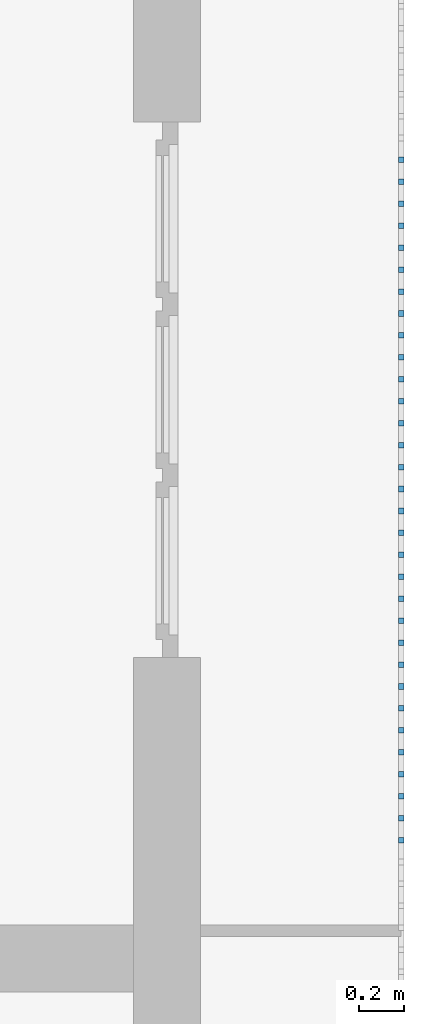
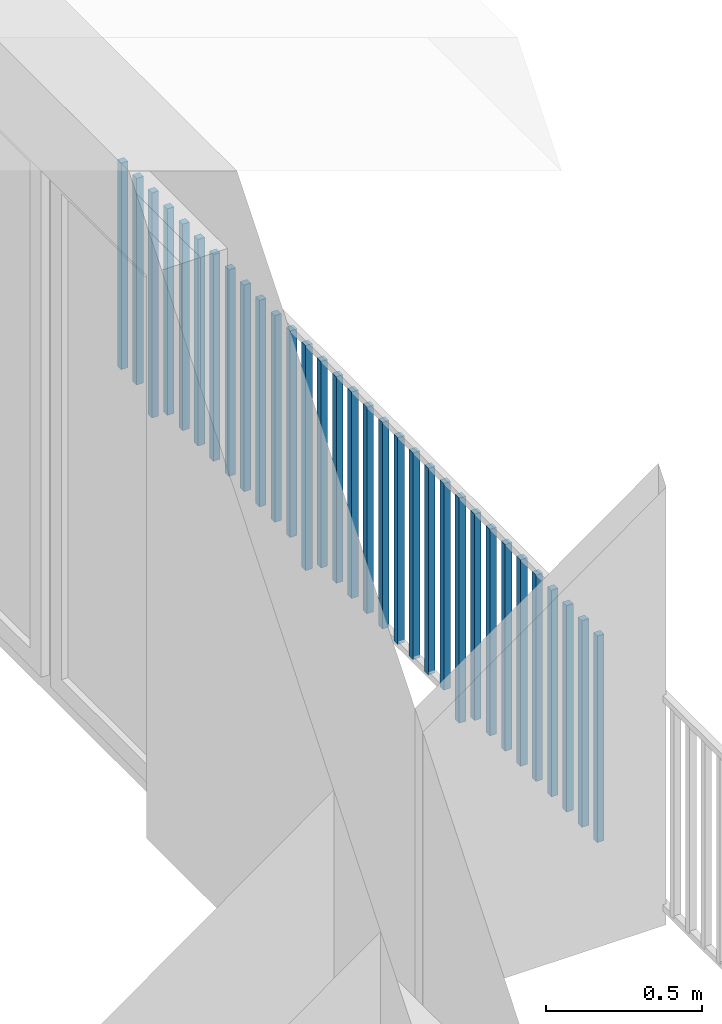
# One storey, part 46 of 54: 32 building element parts, 1 element without a shape of its own.
"""IFC4 building model written with IfcOpenShell, lengths in metres."""

from ifc_helpers import new_model, entity, si_unit, converted_unit, derived_unit, direction, frame, origin_with_axes, place, context, subcontext, project, spatial, polygons, material, type_object, element, aggregate, save


model = new_model("IFC4")

# Units and contexts
model_context = context("Model", 3, precision=1e-05, world=origin_with_axes(), true_north=direction((0.0, 1.0)))
body_context = subcontext(model_context, "Body", "Model", "MODEL_VIEW")
ifc_project = project(units=[si_unit("LENGTHUNIT", "METRE"), si_unit("AREAUNIT", "SQUARE_METRE"), si_unit("VOLUMEUNIT", "CUBIC_METRE"), converted_unit("PLANEANGLEUNIT", "DEGREE", entity("IfcPlaneAngleMeasure", 0.0174532925199), si_unit("PLANEANGLEUNIT", "RADIAN"), dimensions=[0, 0, 0, 0, 0, 0, 0]), converted_unit("TIMEUNIT", "Year", entity("IfcTimeMeasure", 31556926.0), si_unit("TIMEUNIT", "SECOND"), dimensions=[0, 0, 1, 0, 0, 0, 0]), si_unit("MASSUNIT", "GRAM", prefix="KILO"), si_unit("THERMODYNAMICTEMPERATUREUNIT", "DEGREE_CELSIUS"), si_unit("LUMINOUSINTENSITYUNIT", "LUMEN"), si_unit("ENERGYUNIT", "JOULE", prefix="MEGA"), derived_unit("THERMALCONDUCTANCEUNIT", [(si_unit("POWERUNIT", "WATT"), 1), (si_unit("LENGTHUNIT", "METRE"), -1), (si_unit("THERMODYNAMICTEMPERATUREUNIT", "KELVIN"), -1)]), derived_unit("SPECIFICHEATCAPACITYUNIT", [(si_unit("ENERGYUNIT", "JOULE"), 1), (si_unit("MASSUNIT", "GRAM", prefix="KILO"), -1), (si_unit("THERMODYNAMICTEMPERATUREUNIT", "KELVIN"), -1)]), derived_unit("MASSDENSITYUNIT", [(si_unit("MASSUNIT", "GRAM", prefix="KILO"), 1), (si_unit("VOLUMEUNIT", "CUBIC_METRE"), -1)])], contexts=[model_context])

# Site, building, storey, space
site_placement = place(None, origin_with_axes())
site = spatial("IfcSite", under=ifc_project, at=site_placement, CompositionType="ELEMENT")
building_placement = place(site_placement, origin_with_axes())
building = spatial("IfcBuilding", under=site, at=building_placement, CompositionType="ELEMENT")
storey_placement = place(building_placement, frame((0.0, 0.0, 6.29), z_axis=(0.0, 0.0, 1.0), x_axis=(1.0, 0.0, 0.0)))
storey = spatial("IfcBuildingStorey", under=building, at=storey_placement, Name="2. Geschoss", CompositionType="ELEMENT", Elevation=6.29)
space_placement = place(storey_placement, frame((10.2378006196, 9.82118769833, 0.0), z_axis=(0.0, 0.0, 1.0), x_axis=(-1.0, 0.0, 0.0)))
space = spatial("IfcSpace", under=storey, at=space_placement, CompositionType="ELEMENT", PredefinedType="EXTERNAL")

# Railing, building element parts
railing_type = type_object("IfcRailingType", PredefinedType="NOTDEFINED")
railing_placement = place(space_placement, frame((0.0, -7.06315681498e-08, 0.0), z_axis=(0.0, 0.0, 1.0), x_axis=(-1.0, 0.0, 0.0)))
railing = element("IfcRailing", 1, at=railing_placement, inside=space, type_object=railing_type, PredefinedType="NOTDEFINED")
ifc_material = material()
building_element_part_1_placement = place(railing_placement, origin_with_axes())
building_element_part_1 = element("IfcBuildingElementPart", 2, at=building_element_part_1_placement, material=ifc_material, PredefinedType="NOTDEFINED", context=body_context, shape_type="Tessellation", body=[
    polygons([(0.0125, -7.75583333333, 0.07), (-0.0125, -7.75583333333, 0.07), (-0.0125, -7.75583333333, 0.8775), (0.0125, -7.75583333333, 0.8775), (0.0125, -7.78083333333, 0.07), (-0.0125, -7.78083333333, 0.07), (-0.0125, -7.78083333333, 0.8775), (0.0125, -7.78083333333, 0.8775)], [[[1, 2, 3, 4]], [[1, 5, 6, 2]], [[2, 6, 7, 3]], [[4, 3, 7, 8]], [[5, 1, 4, 8]], [[6, 5, 8, 7]]], closed=True),
])
building_element_part_2_placement = place(railing_placement, origin_with_axes())
building_element_part_2 = element("IfcBuildingElementPart", 3, at=building_element_part_2_placement, material=ifc_material, PredefinedType="NOTDEFINED", context=body_context, shape_type="Tessellation", body=[
    polygons([(0.0125, -7.6575, 0.07), (-0.0125, -7.6575, 0.07), (-0.0125, -7.6575, 0.8775), (0.0125, -7.6575, 0.8775), (0.0125, -7.6825, 0.07), (-0.0125, -7.6825, 0.07), (-0.0125, -7.6825, 0.8775), (0.0125, -7.6825, 0.8775)], [[[1, 2, 3, 4]], [[1, 5, 6, 2]], [[2, 6, 7, 3]], [[4, 3, 7, 8]], [[5, 1, 4, 8]], [[6, 5, 8, 7]]], closed=True),
])
building_element_part_3_placement = place(railing_placement, origin_with_axes())
building_element_part_3 = element("IfcBuildingElementPart", 4, at=building_element_part_3_placement, material=ifc_material, PredefinedType="NOTDEFINED", context=body_context, shape_type="Tessellation", body=[
    polygons([(0.0125, -7.55916666667, 0.07), (-0.0125, -7.55916666667, 0.07), (-0.0125, -7.55916666667, 0.8775), (0.0125, -7.55916666667, 0.8775), (0.0125, -7.58416666667, 0.07), (-0.0125, -7.58416666667, 0.07), (-0.0125, -7.58416666667, 0.8775), (0.0125, -7.58416666667, 0.8775)], [[[1, 2, 3, 4]], [[1, 5, 6, 2]], [[2, 6, 7, 3]], [[4, 3, 7, 8]], [[5, 1, 4, 8]], [[6, 5, 8, 7]]], closed=True),
])
building_element_part_4_placement = place(railing_placement, origin_with_axes())
building_element_part_4 = element("IfcBuildingElementPart", 5, at=building_element_part_4_placement, material=ifc_material, PredefinedType="NOTDEFINED", context=body_context, shape_type="Tessellation", body=[
    polygons([(0.0125, -7.46083333333, 0.07), (-0.0125, -7.46083333333, 0.07), (-0.0125, -7.46083333333, 0.8775), (0.0125, -7.46083333333, 0.8775), (0.0125, -7.48583333333, 0.07), (-0.0125, -7.48583333333, 0.07), (-0.0125, -7.48583333333, 0.8775), (0.0125, -7.48583333333, 0.8775)], [[[1, 2, 3, 4]], [[1, 5, 6, 2]], [[2, 6, 7, 3]], [[4, 3, 7, 8]], [[5, 1, 4, 8]], [[6, 5, 8, 7]]], closed=True),
])
building_element_part_5_placement = place(railing_placement, origin_with_axes())
building_element_part_5 = element("IfcBuildingElementPart", 6, at=building_element_part_5_placement, material=ifc_material, PredefinedType="NOTDEFINED", context=body_context, shape_type="Tessellation", body=[
    polygons([(0.0125, -7.3625, 0.07), (-0.0125, -7.3625, 0.07), (-0.0125, -7.3625, 0.8775), (0.0125, -7.3625, 0.8775), (0.0125, -7.3875, 0.07), (-0.0125, -7.3875, 0.07), (-0.0125, -7.3875, 0.8775), (0.0125, -7.3875, 0.8775)], [[[1, 2, 3, 4]], [[1, 5, 6, 2]], [[2, 6, 7, 3]], [[4, 3, 7, 8]], [[5, 1, 4, 8]], [[6, 5, 8, 7]]], closed=True),
])
building_element_part_6_placement = place(railing_placement, origin_with_axes())
building_element_part_6 = element("IfcBuildingElementPart", 7, at=building_element_part_6_placement, material=ifc_material, PredefinedType="NOTDEFINED", context=body_context, shape_type="Tessellation", body=[
    polygons([(0.0125, -7.26416666667, 0.07), (-0.0125, -7.26416666667, 0.07), (-0.0125, -7.26416666667, 0.8775), (0.0125, -7.26416666667, 0.8775), (0.0125, -7.28916666667, 0.07), (-0.0125, -7.28916666667, 0.07), (-0.0125, -7.28916666667, 0.8775), (0.0125, -7.28916666667, 0.8775)], [[[1, 2, 3, 4]], [[1, 5, 6, 2]], [[2, 6, 7, 3]], [[4, 3, 7, 8]], [[5, 1, 4, 8]], [[6, 5, 8, 7]]], closed=True),
])
building_element_part_7_placement = place(railing_placement, origin_with_axes())
building_element_part_7 = element("IfcBuildingElementPart", 8, at=building_element_part_7_placement, material=ifc_material, PredefinedType="NOTDEFINED", context=body_context, shape_type="Tessellation", body=[
    polygons([(0.0125, -7.16583333333, 0.07), (-0.0125, -7.16583333333, 0.07), (-0.0125, -7.16583333333, 0.8775), (0.0125, -7.16583333333, 0.8775), (0.0125, -7.19083333333, 0.07), (-0.0125, -7.19083333333, 0.07), (-0.0125, -7.19083333333, 0.8775), (0.0125, -7.19083333333, 0.8775)], [[[1, 2, 3, 4]], [[1, 5, 6, 2]], [[2, 6, 7, 3]], [[4, 3, 7, 8]], [[5, 1, 4, 8]], [[6, 5, 8, 7]]], closed=True),
])
building_element_part_8_placement = place(railing_placement, origin_with_axes())
building_element_part_8 = element("IfcBuildingElementPart", 9, at=building_element_part_8_placement, material=ifc_material, PredefinedType="NOTDEFINED", context=body_context, shape_type="Tessellation", body=[
    polygons([(0.0125, -7.0675, 0.07), (-0.0125, -7.0675, 0.07), (-0.0125, -7.0675, 0.8775), (0.0125, -7.0675, 0.8775), (0.0125, -7.0925, 0.07), (-0.0125, -7.0925, 0.07), (-0.0125, -7.0925, 0.8775), (0.0125, -7.0925, 0.8775)], [[[1, 2, 3, 4]], [[1, 5, 6, 2]], [[2, 6, 7, 3]], [[4, 3, 7, 8]], [[5, 1, 4, 8]], [[6, 5, 8, 7]]], closed=True),
])
building_element_part_9_placement = place(railing_placement, origin_with_axes())
building_element_part_9 = element("IfcBuildingElementPart", 10, at=building_element_part_9_placement, material=ifc_material, PredefinedType="NOTDEFINED", context=body_context, shape_type="Tessellation", body=[
    polygons([(0.0125, -6.96916666667, 0.07), (-0.0125, -6.96916666667, 0.07), (-0.0125, -6.96916666667, 0.8775), (0.0125, -6.96916666667, 0.8775), (0.0125, -6.99416666667, 0.07), (-0.0125, -6.99416666667, 0.07), (-0.0125, -6.99416666667, 0.8775), (0.0125, -6.99416666667, 0.8775)], [[[1, 2, 3, 4]], [[1, 5, 6, 2]], [[2, 6, 7, 3]], [[4, 3, 7, 8]], [[5, 1, 4, 8]], [[6, 5, 8, 7]]], closed=True),
])
building_element_part_10_placement = place(railing_placement, origin_with_axes())
building_element_part_10 = element("IfcBuildingElementPart", 11, at=building_element_part_10_placement, material=ifc_material, PredefinedType="NOTDEFINED", context=body_context, shape_type="Tessellation", body=[
    polygons([(0.0125, -6.87083333333, 0.0), (-0.0125, -6.87083333333, 0.0), (-0.0125, -6.87083333333, 0.88), (0.0125, -6.87083333333, 0.88), (0.0125, -6.89583333333, 0.0), (-0.0125, -6.89583333333, 0.0), (-0.0125, -6.89583333333, 0.88), (0.0125, -6.89583333333, 0.88)], [[[1, 2, 3, 4]], [[1, 5, 6, 2]], [[2, 6, 7, 3]], [[4, 3, 7, 8]], [[5, 1, 4, 8]], [[6, 5, 8, 7]]], closed=True),
])
building_element_part_11_placement = place(railing_placement, origin_with_axes())
building_element_part_11 = element("IfcBuildingElementPart", 12, at=building_element_part_11_placement, material=ifc_material, PredefinedType="NOTDEFINED", context=body_context, shape_type="Tessellation", body=[
    polygons([(0.0125, -6.7725, 0.07), (-0.0125, -6.7725, 0.07), (-0.0125, -6.7725, 0.8775), (0.0125, -6.7725, 0.8775), (0.0125, -6.7975, 0.07), (-0.0125, -6.7975, 0.07), (-0.0125, -6.7975, 0.8775), (0.0125, -6.7975, 0.8775)], [[[1, 2, 3, 4]], [[1, 5, 6, 2]], [[2, 6, 7, 3]], [[4, 3, 7, 8]], [[5, 1, 4, 8]], [[6, 5, 8, 7]]], closed=True),
])
building_element_part_12_placement = place(railing_placement, origin_with_axes())
building_element_part_12 = element("IfcBuildingElementPart", 13, at=building_element_part_12_placement, material=ifc_material, PredefinedType="NOTDEFINED", context=body_context, shape_type="Tessellation", body=[
    polygons([(0.0125, -6.67416666667, 0.07), (-0.0125, -6.67416666667, 0.07), (-0.0125, -6.67416666667, 0.8775), (0.0125, -6.67416666667, 0.8775), (0.0125, -6.69916666667, 0.07), (-0.0125, -6.69916666667, 0.07), (-0.0125, -6.69916666667, 0.8775), (0.0125, -6.69916666667, 0.8775)], [[[1, 2, 3, 4]], [[1, 5, 6, 2]], [[2, 6, 7, 3]], [[4, 3, 7, 8]], [[5, 1, 4, 8]], [[6, 5, 8, 7]]], closed=True),
])
building_element_part_13_placement = place(railing_placement, origin_with_axes())
building_element_part_13 = element("IfcBuildingElementPart", 14, at=building_element_part_13_placement, material=ifc_material, PredefinedType="NOTDEFINED", context=body_context, shape_type="Tessellation", body=[
    polygons([(0.0125, -6.57583333333, 0.07), (-0.0125, -6.57583333333, 0.07), (-0.0125, -6.57583333333, 0.8775), (0.0125, -6.57583333333, 0.8775), (0.0125, -6.60083333333, 0.07), (-0.0125, -6.60083333333, 0.07), (-0.0125, -6.60083333333, 0.8775), (0.0125, -6.60083333333, 0.8775)], [[[1, 2, 3, 4]], [[1, 5, 6, 2]], [[2, 6, 7, 3]], [[4, 3, 7, 8]], [[5, 1, 4, 8]], [[6, 5, 8, 7]]], closed=True),
])
building_element_part_14_placement = place(railing_placement, origin_with_axes())
building_element_part_14 = element("IfcBuildingElementPart", 15, at=building_element_part_14_placement, material=ifc_material, PredefinedType="NOTDEFINED", context=body_context, shape_type="Tessellation", body=[
    polygons([(0.0125, -6.4775, 0.07), (-0.0125, -6.4775, 0.07), (-0.0125, -6.4775, 0.8775), (0.0125, -6.4775, 0.8775), (0.0125, -6.5025, 0.07), (-0.0125, -6.5025, 0.07), (-0.0125, -6.5025, 0.8775), (0.0125, -6.5025, 0.8775)], [[[1, 2, 3, 4]], [[1, 5, 6, 2]], [[2, 6, 7, 3]], [[4, 3, 7, 8]], [[5, 1, 4, 8]], [[6, 5, 8, 7]]], closed=True),
])
building_element_part_15_placement = place(railing_placement, origin_with_axes())
building_element_part_15 = element("IfcBuildingElementPart", 16, at=building_element_part_15_placement, material=ifc_material, PredefinedType="NOTDEFINED", context=body_context, shape_type="Tessellation", body=[
    polygons([(0.0125, -6.37916666667, 0.07), (-0.0125, -6.37916666667, 0.07), (-0.0125, -6.37916666667, 0.8775), (0.0125, -6.37916666667, 0.8775), (0.0125, -6.40416666667, 0.07), (-0.0125, -6.40416666667, 0.07), (-0.0125, -6.40416666667, 0.8775), (0.0125, -6.40416666667, 0.8775)], [[[1, 2, 3, 4]], [[1, 5, 6, 2]], [[2, 6, 7, 3]], [[4, 3, 7, 8]], [[5, 1, 4, 8]], [[6, 5, 8, 7]]], closed=True),
])
building_element_part_16_placement = place(railing_placement, origin_with_axes())
building_element_part_16 = element("IfcBuildingElementPart", 17, at=building_element_part_16_placement, material=ifc_material, PredefinedType="NOTDEFINED", context=body_context, shape_type="Tessellation", body=[
    polygons([(0.0125, -6.28083333333, 0.07), (-0.0125, -6.28083333333, 0.07), (-0.0125, -6.28083333333, 0.8775), (0.0125, -6.28083333333, 0.8775), (0.0125, -6.30583333333, 0.07), (-0.0125, -6.30583333333, 0.07), (-0.0125, -6.30583333333, 0.8775), (0.0125, -6.30583333333, 0.8775)], [[[1, 2, 3, 4]], [[1, 5, 6, 2]], [[2, 6, 7, 3]], [[4, 3, 7, 8]], [[5, 1, 4, 8]], [[6, 5, 8, 7]]], closed=True),
])
building_element_part_17_placement = place(railing_placement, origin_with_axes())
building_element_part_17 = element("IfcBuildingElementPart", 18, at=building_element_part_17_placement, material=ifc_material, PredefinedType="NOTDEFINED", context=body_context, shape_type="Tessellation", body=[
    polygons([(0.0125, -6.1825, 0.07), (-0.0125, -6.1825, 0.07), (-0.0125, -6.1825, 0.8775), (0.0125, -6.1825, 0.8775), (0.0125, -6.2075, 0.07), (-0.0125, -6.2075, 0.07), (-0.0125, -6.2075, 0.8775), (0.0125, -6.2075, 0.8775)], [[[1, 2, 3, 4]], [[1, 5, 6, 2]], [[2, 6, 7, 3]], [[4, 3, 7, 8]], [[5, 1, 4, 8]], [[6, 5, 8, 7]]], closed=True),
])
building_element_part_18_placement = place(railing_placement, origin_with_axes())
building_element_part_18 = element("IfcBuildingElementPart", 19, at=building_element_part_18_placement, material=ifc_material, PredefinedType="NOTDEFINED", context=body_context, shape_type="Tessellation", body=[
    polygons([(0.0125, -6.08416666667, 0.07), (-0.0125, -6.08416666667, 0.07), (-0.0125, -6.08416666667, 0.8775), (0.0125, -6.08416666667, 0.8775), (0.0125, -6.10916666667, 0.07), (-0.0125, -6.10916666667, 0.07), (-0.0125, -6.10916666667, 0.8775), (0.0125, -6.10916666667, 0.8775)], [[[1, 2, 3, 4]], [[1, 5, 6, 2]], [[2, 6, 7, 3]], [[4, 3, 7, 8]], [[5, 1, 4, 8]], [[6, 5, 8, 7]]], closed=True),
])
building_element_part_19_placement = place(railing_placement, origin_with_axes())
building_element_part_19 = element("IfcBuildingElementPart", 20, at=building_element_part_19_placement, material=ifc_material, PredefinedType="NOTDEFINED", context=body_context, shape_type="Tessellation", body=[
    polygons([(0.0125, -5.98583333333, 0.07), (-0.0125, -5.98583333333, 0.07), (-0.0125, -5.98583333333, 0.8775), (0.0125, -5.98583333333, 0.8775), (0.0125, -6.01083333333, 0.07), (-0.0125, -6.01083333333, 0.07), (-0.0125, -6.01083333333, 0.8775), (0.0125, -6.01083333333, 0.8775)], [[[1, 2, 3, 4]], [[1, 5, 6, 2]], [[2, 6, 7, 3]], [[4, 3, 7, 8]], [[5, 1, 4, 8]], [[6, 5, 8, 7]]], closed=True),
])
building_element_part_20_placement = place(railing_placement, origin_with_axes())
building_element_part_20 = element("IfcBuildingElementPart", 21, at=building_element_part_20_placement, material=ifc_material, PredefinedType="NOTDEFINED", context=body_context, shape_type="Tessellation", body=[
    polygons([(0.0125, -5.8875, 0.0), (-0.0125, -5.8875, 0.0), (-0.0125, -5.8875, 0.88), (0.0125, -5.8875, 0.88), (0.0125, -5.9125, 0.0), (-0.0125, -5.9125, 0.0), (-0.0125, -5.9125, 0.88), (0.0125, -5.9125, 0.88)], [[[1, 2, 3, 4]], [[1, 5, 6, 2]], [[2, 6, 7, 3]], [[4, 3, 7, 8]], [[5, 1, 4, 8]], [[6, 5, 8, 7]]], closed=True),
])
building_element_part_21_placement = place(railing_placement, origin_with_axes())
building_element_part_21 = element("IfcBuildingElementPart", 22, at=building_element_part_21_placement, material=ifc_material, PredefinedType="NOTDEFINED", context=body_context, shape_type="Tessellation", body=[
    polygons([(0.0125, -5.78916666667, 0.07), (-0.0125, -5.78916666667, 0.07), (-0.0125, -5.78916666667, 0.8775), (0.0125, -5.78916666667, 0.8775), (0.0125, -5.81416666667, 0.07), (-0.0125, -5.81416666667, 0.07), (-0.0125, -5.81416666667, 0.8775), (0.0125, -5.81416666667, 0.8775)], [[[1, 2, 3, 4]], [[1, 5, 6, 2]], [[2, 6, 7, 3]], [[4, 3, 7, 8]], [[5, 1, 4, 8]], [[6, 5, 8, 7]]], closed=True),
])
building_element_part_22_placement = place(railing_placement, origin_with_axes())
building_element_part_22 = element("IfcBuildingElementPart", 23, at=building_element_part_22_placement, material=ifc_material, PredefinedType="NOTDEFINED", context=body_context, shape_type="Tessellation", body=[
    polygons([(0.0125, -5.69083333333, 0.07), (-0.0125, -5.69083333333, 0.07), (-0.0125, -5.69083333333, 0.8775), (0.0125, -5.69083333333, 0.8775), (0.0125, -5.71583333333, 0.07), (-0.0125, -5.71583333333, 0.07), (-0.0125, -5.71583333333, 0.8775), (0.0125, -5.71583333333, 0.8775)], [[[1, 2, 3, 4]], [[1, 5, 6, 2]], [[2, 6, 7, 3]], [[4, 3, 7, 8]], [[5, 1, 4, 8]], [[6, 5, 8, 7]]], closed=True),
])
building_element_part_23_placement = place(railing_placement, origin_with_axes())
building_element_part_23 = element("IfcBuildingElementPart", 24, at=building_element_part_23_placement, material=ifc_material, PredefinedType="NOTDEFINED", context=body_context, shape_type="Tessellation", body=[
    polygons([(0.0125, -5.5925, 0.07), (-0.0125, -5.5925, 0.07), (-0.0125, -5.5925, 0.8775), (0.0125, -5.5925, 0.8775), (0.0125, -5.6175, 0.07), (-0.0125, -5.6175, 0.07), (-0.0125, -5.6175, 0.8775), (0.0125, -5.6175, 0.8775)], [[[1, 2, 3, 4]], [[1, 5, 6, 2]], [[2, 6, 7, 3]], [[4, 3, 7, 8]], [[5, 1, 4, 8]], [[6, 5, 8, 7]]], closed=True),
])
building_element_part_24_placement = place(railing_placement, origin_with_axes())
building_element_part_24 = element("IfcBuildingElementPart", 25, at=building_element_part_24_placement, material=ifc_material, PredefinedType="NOTDEFINED", context=body_context, shape_type="Tessellation", body=[
    polygons([(0.0125, -5.49416666667, 0.07), (-0.0125, -5.49416666667, 0.07), (-0.0125, -5.49416666667, 0.8775), (0.0125, -5.49416666667, 0.8775), (0.0125, -5.51916666667, 0.07), (-0.0125, -5.51916666667, 0.07), (-0.0125, -5.51916666667, 0.8775), (0.0125, -5.51916666667, 0.8775)], [[[1, 2, 3, 4]], [[1, 5, 6, 2]], [[2, 6, 7, 3]], [[4, 3, 7, 8]], [[5, 1, 4, 8]], [[6, 5, 8, 7]]], closed=True),
])
building_element_part_25_placement = place(railing_placement, origin_with_axes())
building_element_part_25 = element("IfcBuildingElementPart", 26, at=building_element_part_25_placement, material=ifc_material, PredefinedType="NOTDEFINED", context=body_context, shape_type="Tessellation", body=[
    polygons([(0.0125, -5.39583333333, 0.07), (-0.0125, -5.39583333333, 0.07), (-0.0125, -5.39583333333, 0.8775), (0.0125, -5.39583333333, 0.8775), (0.0125, -5.42083333333, 0.07), (-0.0125, -5.42083333333, 0.07), (-0.0125, -5.42083333333, 0.8775), (0.0125, -5.42083333333, 0.8775)], [[[1, 2, 3, 4]], [[1, 5, 6, 2]], [[2, 6, 7, 3]], [[4, 3, 7, 8]], [[5, 1, 4, 8]], [[6, 5, 8, 7]]], closed=True),
])
building_element_part_26_placement = place(railing_placement, origin_with_axes())
building_element_part_26 = element("IfcBuildingElementPart", 27, at=building_element_part_26_placement, material=ifc_material, PredefinedType="NOTDEFINED", context=body_context, shape_type="Tessellation", body=[
    polygons([(0.0125, -5.2975, 0.07), (-0.0125, -5.2975, 0.07), (-0.0125, -5.2975, 0.8775), (0.0125, -5.2975, 0.8775), (0.0125, -5.3225, 0.07), (-0.0125, -5.3225, 0.07), (-0.0125, -5.3225, 0.8775), (0.0125, -5.3225, 0.8775)], [[[1, 2, 3, 4]], [[1, 5, 6, 2]], [[2, 6, 7, 3]], [[4, 3, 7, 8]], [[5, 1, 4, 8]], [[6, 5, 8, 7]]], closed=True),
])
building_element_part_27_placement = place(railing_placement, origin_with_axes())
building_element_part_27 = element("IfcBuildingElementPart", 28, at=building_element_part_27_placement, material=ifc_material, PredefinedType="NOTDEFINED", context=body_context, shape_type="Tessellation", body=[
    polygons([(0.0125, -5.19916666667, 0.07), (-0.0125, -5.19916666667, 0.07), (-0.0125, -5.19916666667, 0.8775), (0.0125, -5.19916666667, 0.8775), (0.0125, -5.22416666667, 0.07), (-0.0125, -5.22416666667, 0.07), (-0.0125, -5.22416666667, 0.8775), (0.0125, -5.22416666667, 0.8775)], [[[1, 2, 3, 4]], [[1, 5, 6, 2]], [[2, 6, 7, 3]], [[4, 3, 7, 8]], [[5, 1, 4, 8]], [[6, 5, 8, 7]]], closed=True),
])
building_element_part_28_placement = place(railing_placement, origin_with_axes())
building_element_part_28 = element("IfcBuildingElementPart", 29, at=building_element_part_28_placement, material=ifc_material, PredefinedType="NOTDEFINED", context=body_context, shape_type="Tessellation", body=[
    polygons([(0.0125, -5.10083333333, 0.07), (-0.0125, -5.10083333333, 0.07), (-0.0125, -5.10083333333, 0.8775), (0.0125, -5.10083333333, 0.8775), (0.0125, -5.12583333333, 0.07), (-0.0125, -5.12583333333, 0.07), (-0.0125, -5.12583333333, 0.8775), (0.0125, -5.12583333333, 0.8775)], [[[1, 2, 3, 4]], [[1, 5, 6, 2]], [[2, 6, 7, 3]], [[4, 3, 7, 8]], [[5, 1, 4, 8]], [[6, 5, 8, 7]]], closed=True),
])
building_element_part_29_placement = place(railing_placement, origin_with_axes())
building_element_part_29 = element("IfcBuildingElementPart", 30, at=building_element_part_29_placement, material=ifc_material, PredefinedType="NOTDEFINED", context=body_context, shape_type="Tessellation", body=[
    polygons([(0.0125, -5.0025, 0.07), (-0.0125, -5.0025, 0.07), (-0.0125, -5.0025, 0.8775), (0.0125, -5.0025, 0.8775), (0.0125, -5.0275, 0.07), (-0.0125, -5.0275, 0.07), (-0.0125, -5.0275, 0.8775), (0.0125, -5.0275, 0.8775)], [[[1, 2, 3, 4]], [[1, 5, 6, 2]], [[2, 6, 7, 3]], [[4, 3, 7, 8]], [[5, 1, 4, 8]], [[6, 5, 8, 7]]], closed=True),
])
building_element_part_30_placement = place(railing_placement, origin_with_axes())
building_element_part_30 = element("IfcBuildingElementPart", 31, at=building_element_part_30_placement, material=ifc_material, PredefinedType="NOTDEFINED", context=body_context, shape_type="Tessellation", body=[
    polygons([(0.0125, -4.90416666667, 0.0), (-0.0125, -4.90416666667, 0.0), (-0.0125, -4.90416666667, 0.88), (0.0125, -4.90416666667, 0.88), (0.0125, -4.92916666667, 0.0), (-0.0125, -4.92916666667, 0.0), (-0.0125, -4.92916666667, 0.88), (0.0125, -4.92916666667, 0.88)], [[[1, 2, 3, 4]], [[1, 5, 6, 2]], [[2, 6, 7, 3]], [[4, 3, 7, 8]], [[5, 1, 4, 8]], [[6, 5, 8, 7]]], closed=True),
])
building_element_part_31_placement = place(railing_placement, origin_with_axes())
building_element_part_31 = element("IfcBuildingElementPart", 32, at=building_element_part_31_placement, material=ifc_material, PredefinedType="NOTDEFINED", context=body_context, shape_type="Tessellation", body=[
    polygons([(0.0125, -4.80583333333, 0.07), (-0.0125, -4.80583333333, 0.07), (-0.0125, -4.80583333333, 0.8775), (0.0125, -4.80583333333, 0.8775), (0.0125, -4.83083333333, 0.07), (-0.0125, -4.83083333333, 0.07), (-0.0125, -4.83083333333, 0.8775), (0.0125, -4.83083333333, 0.8775)], [[[1, 2, 3, 4]], [[1, 5, 6, 2]], [[2, 6, 7, 3]], [[4, 3, 7, 8]], [[5, 1, 4, 8]], [[6, 5, 8, 7]]], closed=True),
])
building_element_part_32_placement = place(railing_placement, origin_with_axes())
building_element_part_32 = element("IfcBuildingElementPart", 33, at=building_element_part_32_placement, material=ifc_material, PredefinedType="NOTDEFINED", context=body_context, shape_type="Tessellation", body=[
    polygons([(0.0125, -4.7075, 0.07), (-0.0125, -4.7075, 0.07), (-0.0125, -4.7075, 0.8775), (0.0125, -4.7075, 0.8775), (0.0125, -4.7325, 0.07), (-0.0125, -4.7325, 0.07), (-0.0125, -4.7325, 0.8775), (0.0125, -4.7325, 0.8775)], [[[1, 2, 3, 4]], [[1, 5, 6, 2]], [[2, 6, 7, 3]], [[4, 3, 7, 8]], [[5, 1, 4, 8]], [[6, 5, 8, 7]]], closed=True),
])
aggregate(railing, [building_element_part_1, building_element_part_2, building_element_part_3, building_element_part_4, building_element_part_5, building_element_part_6, building_element_part_7, building_element_part_8, building_element_part_9, building_element_part_10, building_element_part_11, building_element_part_12, building_element_part_13, building_element_part_14, building_element_part_15, building_element_part_16, building_element_part_17, building_element_part_18, building_element_part_19, building_element_part_20, building_element_part_21, building_element_part_22, building_element_part_23, building_element_part_24, building_element_part_25, building_element_part_26, building_element_part_27, building_element_part_28, building_element_part_29, building_element_part_30, building_element_part_31, building_element_part_32])

save(model, "model.ifc")
